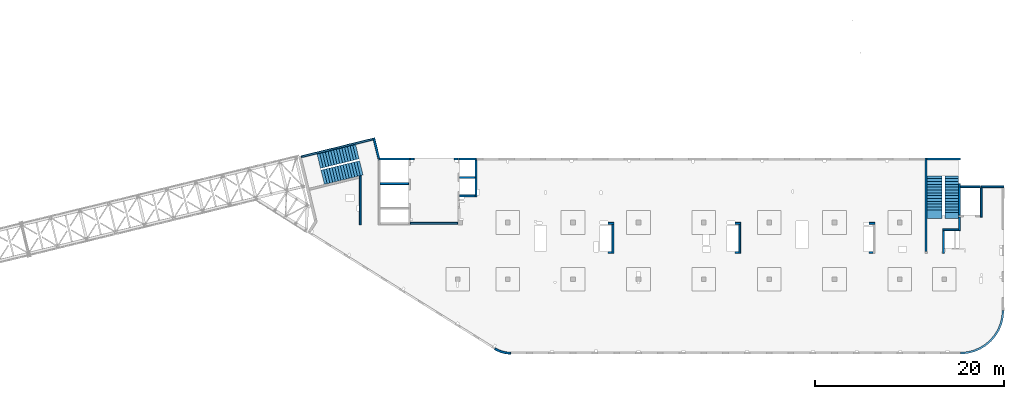
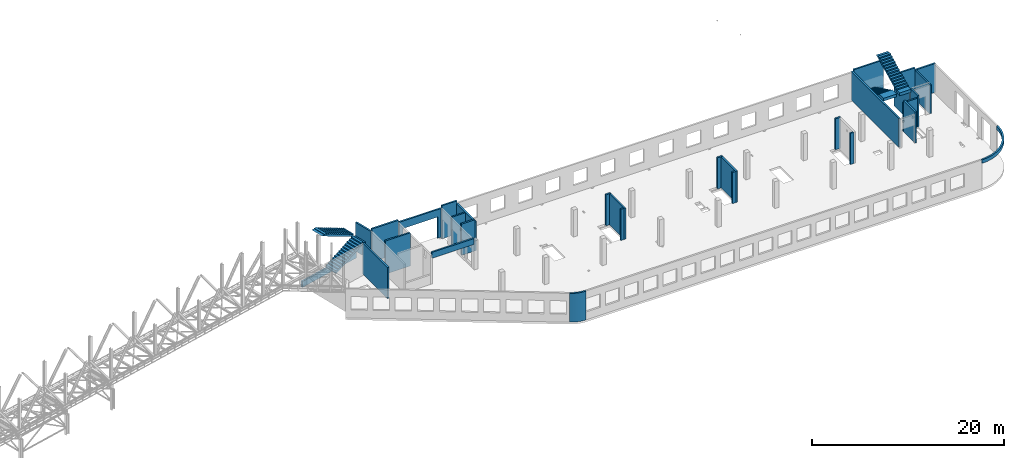
# One storey, part 21 of 93: 30 walls, 4 stairs, 1 opening.
"""IFC4 building model written with IfcOpenShell, lengths in millimetres."""

from ifc_helpers import new_model, entity, si_unit, converted_unit, derived_unit, direction, frame, origin, place, context, subcontext, project, spatial, indexed_curve, outline, extrude, polygons, material, type_object, element, save


model = new_model("IFC4")

# Units and contexts
model_context = context("Model", 3, precision=0.01, world=origin(), true_north=direction((6.12303176911189e-17, 1.0)))
plan_context = context("Plan", 3, precision=0.01, world=origin(), true_north=direction((6.12303176911189e-17, 1.0)))
body_context = subcontext(model_context, "Body", "Model", "MODEL_VIEW")
ifc_project = project(units=[si_unit("LENGTHUNIT", "METRE", prefix="MILLI"), si_unit("AREAUNIT", "SQUARE_METRE"), si_unit("VOLUMEUNIT", "CUBIC_METRE"), converted_unit("PLANEANGLEUNIT", "DEGREE", entity("IfcRatioMeasure", 0.0174532925199433), si_unit("PLANEANGLEUNIT", "RADIAN"), dimensions=[0, 0, 0, 0, 0, 0, 0]), si_unit("MASSUNIT", "GRAM", prefix="KILO"), derived_unit("MASSDENSITYUNIT", [(si_unit("MASSUNIT", "GRAM", prefix="KILO"), 1), (si_unit("LENGTHUNIT", "METRE"), -3)]), derived_unit("MOMENTOFINERTIAUNIT", [(si_unit("LENGTHUNIT", "METRE"), 4)]), si_unit("TIMEUNIT", "SECOND"), si_unit("FREQUENCYUNIT", "HERTZ"), si_unit("THERMODYNAMICTEMPERATUREUNIT", "DEGREE_CELSIUS"), derived_unit("THERMALTRANSMITTANCEUNIT", [(si_unit("MASSUNIT", "GRAM", prefix="KILO"), 1), (si_unit("THERMODYNAMICTEMPERATUREUNIT", "KELVIN"), -1), (si_unit("TIMEUNIT", "SECOND"), -3)]), derived_unit("VOLUMETRICFLOWRATEUNIT", [(si_unit("LENGTHUNIT", "METRE"), 3), (si_unit("TIMEUNIT", "SECOND"), -1)]), derived_unit("MASSFLOWRATEUNIT", [(si_unit("MASSUNIT", "GRAM", prefix="KILO"), 1), (si_unit("TIMEUNIT", "SECOND"), -1)]), derived_unit("ROTATIONALFREQUENCYUNIT", [(si_unit("TIMEUNIT", "SECOND"), -1)]), si_unit("ELECTRICCURRENTUNIT", "AMPERE"), si_unit("ELECTRICVOLTAGEUNIT", "VOLT"), si_unit("POWERUNIT", "WATT"), si_unit("FORCEUNIT", "NEWTON", prefix="KILO"), si_unit("ILLUMINANCEUNIT", "LUX"), si_unit("LUMINOUSFLUXUNIT", "LUMEN"), si_unit("LUMINOUSINTENSITYUNIT", "CANDELA"), derived_unit("USERDEFINED", [(si_unit("MASSUNIT", "GRAM", prefix="KILO"), -1), (si_unit("LENGTHUNIT", "METRE"), -2), (si_unit("TIMEUNIT", "SECOND"), 3), (si_unit("LUMINOUSFLUXUNIT", "LUMEN"), 1)]), derived_unit("LINEARVELOCITYUNIT", [(si_unit("LENGTHUNIT", "METRE"), 1), (si_unit("TIMEUNIT", "SECOND"), -1)]), si_unit("PRESSUREUNIT", "PASCAL"), derived_unit("USERDEFINED", [(si_unit("LENGTHUNIT", "METRE"), -2), (si_unit("MASSUNIT", "GRAM", prefix="KILO"), 1), (si_unit("TIMEUNIT", "SECOND"), -2)]), derived_unit("LINEARFORCEUNIT", [(si_unit("MASSUNIT", "GRAM", prefix="KILO"), 1), (si_unit("LENGTHUNIT", "METRE"), 1), (si_unit("TIMEUNIT", "SECOND"), -2), (si_unit("LENGTHUNIT", "METRE"), -1)]), derived_unit("PLANARFORCEUNIT", [(si_unit("MASSUNIT", "GRAM", prefix="KILO"), 1), (si_unit("LENGTHUNIT", "METRE"), 1), (si_unit("TIMEUNIT", "SECOND"), -2), (si_unit("LENGTHUNIT", "METRE"), -2)])], contexts=[model_context, plan_context])

# Site, building, storey
site_placement = place(None, origin())
site = spatial("IfcSite", under=ifc_project, at=site_placement, CompositionType="ELEMENT")
building_placement = place(site_placement, origin())
building = spatial("IfcBuilding", under=site, at=building_placement, CompositionType="ELEMENT")
storey_placement = place(building_placement, frame((0.0, 0.0, 15900.0)))
storey = spatial("IfcBuildingStorey", under=building, at=storey_placement, CompositionType="ELEMENT", Elevation=15900.0)

# Walls
ifc_material_1 = material()
wall_type = type_object("IfcWallType", PredefinedType="STANDARD")
wall_1_placement = place(storey_placement, frame((71069.9994506836, 17469.9992263555, -150.0)))
element("IfcWall", 1, at=wall_1_placement, inside=storey, type_object=wall_type, material=ifc_material_1, PredefinedType="NOTDEFINED", context=body_context, shape_type="SweptSolid", body=[
    extrude(outline(indexed_curve([(2500.00000000001, -99.9999999999999), (2500.00000000001, 100.0), (99.9999999999943, 99.9999999999992), (99.9999999999949, -100.000000000001), (199.999999999998, -100.0), (2300.00000000001, -100.0), (2500.00000000001, -99.9999999999999)], self_intersect=False)), origin(), (0.0, 0.0, 1.0), 3650.0),
])
wall_2_placement = place(storey_placement, frame((71169.9994506836, 17369.9992263555, -150.0), z_axis=(0.0, 0.0, 1.0), x_axis=(0.0, -1.0, 0.0)))
element("IfcWall", 2, at=wall_2_placement, inside=storey, type_object=wall_type, material=ifc_material_1, PredefinedType="NOTDEFINED", context=body_context, shape_type="SweptSolid", body=[
    extrude(outline(indexed_curve([(3100.0, 100.000000000003), (-2.79449581754433e-13, 100.000000000003), (2.79449581754433e-13, -100.000000000003), (3100.0, -100.000000000003), (3100.0, 100.000000000003)], self_intersect=False)), origin(), (0.0, 0.0, 1.0), 3650.0),
])
wall_3_placement = place(storey_placement, frame((68870.0002685547, 14269.9992263555, -150.0), z_axis=(0.0, 0.0, 1.0), x_axis=(0.0, -1.0, 0.0)))
element("IfcWall", 3, at=wall_3_placement, inside=storey, type_object=wall_type, material=ifc_material_1, PredefinedType="NOTDEFINED", context=body_context, shape_type="SweptSolid", body=[
    extrude(outline(indexed_curve([(1439.99999999999, 100.000000000003), (0.0, 100.000000000003), (0.0, -100.000000000003), (1439.99999999999, -100.000000000003), (1439.99999999999, 100.000000000003)], self_intersect=False)), origin(), (0.0, 0.0, 1.0), 3950.0),
])
wall_4_placement = place(storey_placement, frame((68770.0002685547, 12929.9992263555, -150.0), z_axis=(0.0, 0.0, 1.0), x_axis=(-1.0, 0.0, 0.0)))
element("IfcWall", 4, at=wall_4_placement, inside=storey, type_object=wall_type, material=ifc_material_1, PredefinedType="NOTDEFINED", context=body_context, shape_type="SweptSolid", body=[
    extrude(outline(indexed_curve([(1689.99999999997, 99.9999999999989), (-3.84449868389964e-13, 99.9999999999989), (3.84449868389964e-13, -99.9999999999989), (1689.99999999997, -99.9999999999989), (1689.99999999997, 99.9999999999989)], self_intersect=False)), origin(), (0.0, 0.0, 1.0), 3650.0),
])
wall_5_placement = place(storey_placement, frame((67180.0002685547, 12829.9992263555, -150.0), z_axis=(0.0, 0.0, 1.0), x_axis=(0.0, -1.0, 0.0)))
element("IfcWall", 5, at=wall_5_placement, inside=storey, type_object=wall_type, material=ifc_material_1, PredefinedType="NOTDEFINED", context=body_context, shape_type="SweptSolid", body=[
    extrude(outline(indexed_curve([(2404.99999999995, 100.000000000003), (0.0, 100.000000000003), (0.0, -100.000000000003), (2404.99999999995, -100.000000000003), (2404.99999999995, 100.000000000003)], self_intersect=False)), origin(), (0.0, 0.0, 1.0), 3950.0),
])
wall_6_placement = place(storey_placement, frame((65330.0002685547, 10624.9992263555, -150.0), z_axis=(0.0, 0.0, 1.0), x_axis=(0.0, 1.0, 0.0)))
element("IfcWall", 6, at=wall_6_placement, inside=storey, type_object=wall_type, material=ifc_material_1, PredefinedType="NOTDEFINED", context=body_context, shape_type="SweptSolid", body=[
    extrude(outline(indexed_curve([(9875.00063936713, 100.000000000003), (-1.71685740578866e-13, 100.000000000003), (1.71685740578866e-13, -100.000000000003), (9875.00063936713, -100.000000000004), (9875.00063936713, 100.000000000003)], self_intersect=False)), origin(), (0.0, 0.0, 1.0), 3650.0),
])
wall_7_placement = place(storey_placement, frame((68970.0002685545, -99.9999557734324, 3050.0)))
element("IfcWall", 7, at=wall_7_placement, inside=storey, type_object=wall_type, material=ifc_material_1, PredefinedType="NOTDEFINED", context=body_context, shape_type="SweptSolid", body=[
    extrude(outline(indexed_curve([(4399.99918212903, 4499.99918212888), (4345.82789081698, 3811.68766389508), (4184.64789385715, 3140.32465961517), (3920.42797770043, 2502.44135458057), (3559.67411357824, 1913.74455277455), (3111.26925889869, 1388.72992323025), (2586.25462935438, 940.325068550716), (1997.55782754836, 579.571204428538), (1359.67452251375, 315.351288271842), (688.311518233829, 154.171291312031), (3.46517481375486e-11, 100.0), (0.0, -100.0), (719.598411241839, -43.3663768070014), (1421.47792138871, 125.139985012801), (2088.35592749623, 401.369899590849), (2703.81167981284, 778.521669675706), (3252.69061513597, 1247.30856699292), (3721.47751245321, 1796.18750231603), (4098.6292825381, 2411.64325463263), (4374.85919711618, 3078.52126074015), (4543.365558936, 3780.40077088701), (4599.99918212903, 4499.99918212885), (4399.99918212903, 4499.99918212888)], self_intersect=False)), origin(), (0.0, 0.0, 1.0), 450.000000000002),
])
wall_8_placement = place(storey_placement, frame((19822.3508916672, 371.159404898124, -150.0)))
element("IfcWall", 8, at=wall_8_placement, inside=storey, type_object=wall_type, material=ifc_material_1, PredefinedType="NOTDEFINED", context=body_context, shape_type="SweptSolid", body=[
    extrude(outline(indexed_curve([(1647.48298908956, -371.159642137684), (1479.53495854193, -366.732336838998), (1312.09852486252, -352.905454552832), (1145.69934172072, -329.72240370142), (980.859806418502, -297.255965670987), (818.09741986465, -255.608066320247), (657.923161920899, -204.909455992096), (500.839887220395, -145.319299033065), (347.340746494629, -77.024674109233), (197.907638365059, -0.239986887291593), (53.0096964598414, 84.7937030753815), (-53.0096964598197, -84.7937030753918), (101.553010904459, -175.499182842681), (260.953382356765, -257.405447245706), (424.69099282044, -330.255357933605), (592.251800794088, -393.820208274097), (763.109762144871, -447.900441360165), (936.728481583211, -492.326276503471), (1112.5628966341, -526.958242247616), (1290.06098881835, -551.687614227945), (1468.66551667174, -566.436756503237), (1647.81576516126, -571.159365287708), (1647.48298908956, -371.159642137684)], self_intersect=False)), origin(), (0.0, 0.0, 1.0), 3650.0),
])
wall_9_placement = place(storey_placement, frame((17825.0002685547, 20299.9998657227, -150.0), z_axis=(0.0, 0.0, 1.0), x_axis=(0.0, -1.0, 0.0)))
element("IfcWall", 9, at=wall_9_placement, inside=storey, type_object=wall_type, material=ifc_material_1, PredefinedType="NOTDEFINED", context=body_context, shape_type="SweptSolid", body=[
    extrude(outline(indexed_curve([(3900.00063936684, 99.9999999999989), (-1.66594915657375e-13, 99.9999999999989), (1.66594915657375e-13, -99.9999999999989), (3900.00063936684, -99.9999999999989), (3900.00063936684, 99.9999999999989)], self_intersect=False)), origin(), (0.0, 0.0, 1.0), 3650.0),
])
wall_10_placement = place(storey_placement, frame((17725.0002685547, 16499.9992263558, -150.0), z_axis=(0.0, 0.0, 1.0), x_axis=(-1.0, 0.0, 0.0)))
element("IfcWall", 10, at=wall_10_placement, inside=storey, type_object=wall_type, material=ifc_material_1, PredefinedType="NOTDEFINED", context=body_context, shape_type="SweptSolid", body=[
    extrude(outline(indexed_curve([(1624.99999999999, 99.9999999999982), (-3.56011111002209e-13, 99.9999999999989), (3.56011111002209e-13, -99.9999999999989), (1624.99999999999, -99.9999999999996), (1624.99999999999, 99.9999999999982)], self_intersect=False)), origin(), (0.0, 0.0, 1.0), 3950.0),
])
wall_11_placement = place(storey_placement, frame((5600.00026855469, 13449.9992263559, -150.0), z_axis=(0.0, 0.0, 1.0), x_axis=(0.0, 1.0, 0.0)))
element("IfcWall", 11, at=wall_11_placement, inside=storey, type_object=wall_type, material=ifc_material_1, PredefinedType="NOTDEFINED", context=body_context, shape_type="SweptSolid", body=[
    extrude(outline(indexed_curve([(5191.05764338749, -100.0), (5142.30552742916, 99.9999999999995), (4936.44934265344, 100.0), (-1.37676332088153e-13, 100.0), (1.37676332088153e-13, -100.0), (5191.05764338749, -100.0)], self_intersect=False)), origin(), (0.0, 0.0, 1.0), 3950.0),
])

# Wall, opening
wall_12_placement = place(storey_placement, frame((10900.0002685547, 20399.9998657227, -150.0)))
wall_12 = element("IfcWall", 12, at=wall_12_placement, inside=storey, type_object=wall_type, material=ifc_material_1, PredefinedType="NOTDEFINED", context=body_context, shape_type="Tessellation", body=[
    polygons([(5000.0, -100.000000000003, 3650.0), (-4.99784381508401e-13, -100.000000000003, 3650.0), (-4.99784381508401e-13, -100.000000000003, -2.16573425859679e-12), (399.999999999991, -99.9999999999989, -2.16573425859679e-12), (399.999999999993, -100.000000000003, 2699.99999999805), (4599.99999999999, -100.000000000003, 2699.99999999804), (4599.99999999999, -100.000000000003, -2.16573425859679e-12), (5000.0, -100.000000000003, -2.16573425859679e-12), (-1.16616415338434e-12, 99.9999999999989, 3650.0), (5000.0, 99.9999999999989, 3650.0), (5000.0, 99.9999999999989, 49.9999999999973), (5000.0, 99.9999999999989, -2.16573425859679e-12), (4599.99999999999, 99.9999999999989, -2.16573425859679e-12), (4599.99999999999, 99.9999999999989, 2699.99999999804), (399.999999999992, 100.000000000003, 2699.99999999805), (399.999999999992, 100.000000000003, -2.16573425859679e-12), (-1.16616415338434e-12, 99.9999999999989, -2.16573425859679e-12), (-1.16616415338434e-12, 99.9999999999989, 49.9999999999973)], [[[1, 2, 3, 4, 5, 6, 7, 8]], [[9, 10, 11, 12, 13, 14, 15, 16, 17, 18]], [[3, 17, 16, 4]], [[2, 1, 10, 9]], [[5, 15, 14, 6]], [[6, 14, 13, 7]], [[15, 5, 4, 16]], [[8, 12, 11, 10, 1]], [[17, 3, 2, 9, 18]], [[12, 8, 7, 13]]], closed=True),
])
opening_placement = place(wall_12_placement, frame((-10900.0002685547, -20399.9998657227, 150.0)))
element("IfcOpeningElement", 13, at=opening_placement, cuts=wall_12, PredefinedType="OPENING", context=body_context, shape_type="SweptSolid", body=[
    extrude(outline(indexed_curve([(-2100.0, -1349.99999999902), (2100.0, -1349.99999999902), (2100.0, 1349.99999999902), (-2100.0, 1349.99999999902), (-2100.0, -1349.99999999902)], self_intersect=False)), frame((13400.0002685547, 20199.9998657207, 1200.0), z_axis=(0.0, 1.0, 0.0), x_axis=(1.0, 0.0, 0.0)), (0.0, 0.0, 1.0), 400.000000001945),
])

# Walls
wall_13_placement = place(storey_placement, frame((68870.0002685547, 17779.9992263555, -400.0), z_axis=(0.0, 0.0, 1.0), x_axis=(0.0, -1.0, 0.0)))
element("IfcWall", 14, at=wall_13_placement, inside=storey, type_object=wall_type, material=ifc_material_1, PredefinedType="NOTDEFINED", context=body_context, shape_type="Tessellation", body=[
    polygons([(2.16573425859679e-12, -99.9999999999946, 0.0), (3310.0, -99.9999999999946, 0.0), (3310.0, -99.9999999999946, 299.999999999997), (3310.0, -99.9999999999946, 3900.0), (2.16573425859679e-12, -99.9999999999946, 3900.0), (3310.0, 100.000000000012, 0.0), (410.0, 100.000000000003, 0.0), (210.0, 100.000000000003, 0.0), (2.16573425859679e-12, 100.000000000012, 0.0), (2.16573425859679e-12, 100.000000000012, 3900.0), (3310.0, 100.000000000012, 3900.0)], [[[1, 2, 3, 4, 5]], [[6, 7, 8, 9, 10, 11]], [[2, 1, 9, 8, 7, 6]], [[9, 1, 5, 10]], [[2, 6, 11, 4, 3]], [[5, 4, 11, 10]]], closed=True),
])
wall_14_placement = place(storey_placement, frame((68970.0002685547, 17469.9992263555, -100.0)))
element("IfcWall", 15, at=wall_14_placement, inside=storey, type_object=wall_type, material=ifc_material_1, PredefinedType="NOTDEFINED", context=body_context, shape_type="Tessellation", body=[
    polygons([(2099.99918212888, -100.000000000001, 2.16573425859679e-12), (2099.99918212888, -100.000000000001, 3600.0), (2099.99918212888, -100.000000000001, 3850.0), (2099.99918212888, -100.000000000001, 3900.0), (6.89939203009021e-12, -100.000000000001, 3900.0), (6.89939203009021e-12, -100.000000000001, 2.16573425859679e-12), (6.28061057235613e-12, 99.9999999999989, 3900.0), (2099.99918212888, 99.9999999999989, 3900.0), (2099.99918212888, 99.9999999999989, 3850.0), (2099.99918212888, 99.9999999999989, 3600.0), (2099.99918212888, 99.9999999999989, 2.16573425859679e-12), (6.28061057235613e-12, 99.9999999999989, 2.16573425859679e-12)], [[[1, 2, 3, 4, 5, 6]], [[7, 8, 9, 10, 11, 12]], [[5, 4, 8, 7]], [[5, 7, 12, 6]], [[1, 11, 10, 9, 8, 4, 3, 2]], [[1, 6, 12, 11]]], closed=True),
])
wall_15_placement = place(storey_placement, frame((65430.0002685547, 20399.9998657227, -400.0)))
element("IfcWall", 16, at=wall_15_placement, inside=storey, type_object=wall_type, material=ifc_material_1, PredefinedType="NOTDEFINED", context=body_context, shape_type="SweptSolid", body=[
    extrude(outline(indexed_curve([(3539.99999999995, 99.9999999999989), (-3.67073603151997e-13, 99.9999999999989), (3.67073603151997e-13, -99.9999999999989), (3539.99999999995, -99.9999999999989), (3539.99999999995, 99.9999999999989)], self_intersect=False)), origin(), (0.0, 0.0, 1.0), 4150.0),
])
wall_16_placement = place(storey_placement, frame((16000.0002685547, 20399.9998657227, -400.0)))
element("IfcWall", 17, at=wall_16_placement, inside=storey, type_object=wall_type, material=ifc_material_1, PredefinedType="NOTDEFINED", context=body_context, shape_type="SweptSolid", body=[
    extrude(outline(indexed_curve([(1824.99999999999, -100.000000000003), (1824.99999999999, 99.9999999999995), (1724.99999999999, 99.9999999999992), (99.9999999999987, 99.9999999999992), (-2.66551908750372e-13, 99.9999999999989), (2.66551908750383e-13, -100.000000000003), (1724.99999999999, -100.000000000003), (1824.99999999999, -100.000000000003)], self_intersect=False)), origin(), (0.0, 0.0, 1.0), 4200.0),
])
wall_17_placement = place(storey_placement, frame((16100.0002685547, 18449.9998657227, -400.0)))
element("IfcWall", 18, at=wall_17_placement, inside=storey, type_object=wall_type, material=ifc_material_1, PredefinedType="NOTDEFINED", context=body_context, shape_type="SweptSolid", body=[
    extrude(outline(indexed_curve([(1624.99999999999, 99.9999999999989), (-2.66551908750371e-13, 99.9999999999989), (2.66551908750371e-13, -99.9999999999989), (1624.99999999999, -99.9999999999989), (1624.99999999999, 99.9999999999989)], self_intersect=False)), origin(), (0.0, 0.0, 1.0), 3900.0),
])
wall_18_placement = place(storey_placement, frame((7600.0002685547, 20399.9998657227, -400.0)))
element("IfcWall", 19, at=wall_18_placement, inside=storey, type_object=wall_type, material=ifc_material_1, PredefinedType="NOTDEFINED", context=body_context, shape_type="SweptSolid", body=[
    extrude(outline(indexed_curve([(3200.0, -100.000000000003), (3200.0, 99.9999999999995), (3100.0, 99.9999999999992), (7.9410256148549e-13, 99.9999999999989), (2.88764567812915e-13, -100.000000000003), (3200.0, -100.000000000003)], self_intersect=False)), origin(), (0.0, 0.0, 1.0), 4200.0),
])
wall_19_placement = place(storey_placement, frame((7700.0002685547, 17799.9998657227, -400.0)))
element("IfcWall", 20, at=wall_19_placement, inside=storey, type_object=wall_type, material=ifc_material_1, PredefinedType="NOTDEFINED", context=body_context, shape_type="SweptSolid", body=[
    extrude(outline(indexed_curve([(3000.0, 99.9999999999989), (-2.88764567812902e-13, 99.9999999999989), (2.88764567812902e-13, -99.9999999999989), (3000.0, -99.9999999999989), (3000.0, 99.9999999999989)], self_intersect=False)), origin(), (0.0, 0.0, 1.0), 4200.0),
])
wall_20_placement = place(storey_placement, frame((59330.0002685547, 13599.9992263555, -150.0)))
element("IfcWall", 21, at=wall_20_placement, inside=storey, type_object=wall_type, material=ifc_material_1, PredefinedType="NOTDEFINED", context=body_context, shape_type="SweptSolid", body=[
    extrude(outline(indexed_curve([(599.999999999993, 99.9999999999989), (-3.60955709766131e-13, 99.9999999999989), (3.60955709766131e-13, -99.9999999999989), (599.999999999994, -99.9999999999989), (599.999999999993, 99.9999999999989)], self_intersect=False)), origin(), (0.0, 0.0, 1.0), 3950.0),
])
wall_21_placement = place(storey_placement, frame((59730.0002685547, 10524.9992263555, -150.0), z_axis=(0.0, 0.0, 1.0), x_axis=(-1.0, 0.0, 0.0)))
element("IfcWall", 22, at=wall_21_placement, inside=storey, type_object=wall_type, material=ifc_material_1, PredefinedType="NOTDEFINED", context=body_context, shape_type="SweptSolid", body=[
    extrude(outline(indexed_curve([(399.999999999987, 99.9999999999982), (-3.60955709766136e-13, 99.9999999999989), (3.60955709766136e-13, -99.9999999999989), (399.999999999987, -99.9999999999996), (399.999999999987, 99.9999999999982)], self_intersect=False)), origin(), (0.0, 0.0, 1.0), 3950.0),
])
wall_22_placement = place(storey_placement, frame((45170.0002685547, 13599.9992263556, -150.0)))
element("IfcWall", 23, at=wall_22_placement, inside=storey, type_object=wall_type, material=ifc_material_1, PredefinedType="NOTDEFINED", context=body_context, shape_type="SweptSolid", body=[
    extrude(outline(indexed_curve([(599.999999999993, 99.9999999999989), (-3.60955709766131e-13, 99.9999999999989), (3.60955709766131e-13, -99.9999999999989), (599.999999999994, -99.9999999999989), (599.999999999993, 99.9999999999989)], self_intersect=False)), origin(), (0.0, 0.0, 1.0), 3950.0),
])
wall_23_placement = place(storey_placement, frame((45670.0002685547, 13499.9992263556, -150.0), z_axis=(0.0, 0.0, 1.0), x_axis=(0.0, -1.0, 0.0)))
element("IfcWall", 24, at=wall_23_placement, inside=storey, type_object=wall_type, material=ifc_material_1, PredefinedType="NOTDEFINED", context=body_context, shape_type="SweptSolid", body=[
    extrude(outline(indexed_curve([(3074.99985044015, 100.000000000003), (-2.64517173435081e-13, 100.000000000003), (2.64517173435081e-13, -100.000000000003), (3074.99985044015, -100.000000000004), (3074.99985044015, 100.000000000003)], self_intersect=False)), origin(), (0.0, 0.0, 1.0), 3950.0),
])
wall_24_placement = place(storey_placement, frame((45570.0002685547, 10524.9993759154, -150.0), z_axis=(0.0, 0.0, 1.0), x_axis=(-1.0, 0.0, 0.0)))
element("IfcWall", 25, at=wall_24_placement, inside=storey, type_object=wall_type, material=ifc_material_1, PredefinedType="NOTDEFINED", context=body_context, shape_type="SweptSolid", body=[
    extrude(outline(indexed_curve([(399.999999999995, 99.9999999999982), (-3.60955709766131e-13, 99.9999999999989), (3.60955709766131e-13, -99.9999999999989), (399.999999999996, -99.9999999999996), (399.999999999995, 99.9999999999982)], self_intersect=False)), origin(), (0.0, 0.0, 1.0), 3950.0),
])
wall_25_placement = place(storey_placement, frame((31770.0002685547, 13599.9992263557, -150.0)))
element("IfcWall", 26, at=wall_25_placement, inside=storey, type_object=wall_type, material=ifc_material_1, PredefinedType="NOTDEFINED", context=body_context, shape_type="SweptSolid", body=[
    extrude(outline(indexed_curve([(600.000000000002, 99.9999999999989), (-3.60955709766126e-13, 99.9999999999989), (3.60955709766126e-13, -99.9999999999989), (600.000000000003, -99.9999999999989), (600.000000000002, 99.9999999999989)], self_intersect=False)), origin(), (0.0, 0.0, 1.0), 3950.0),
])
wall_26_placement = place(storey_placement, frame((32270.0002685547, 13499.9992263557, -150.0), z_axis=(0.0, 0.0, 1.0), x_axis=(0.0, -1.0, 0.0)))
element("IfcWall", 27, at=wall_26_placement, inside=storey, type_object=wall_type, material=ifc_material_1, PredefinedType="NOTDEFINED", context=body_context, shape_type="SweptSolid", body=[
    extrude(outline(indexed_curve([(3074.99985044025, 99.9999999999987), (-1.32258586717531e-13, 99.9999999999989), (1.32258586717531e-13, -99.9999999999989), (3074.99985044025, -99.9999999999992), (3074.99985044025, 99.9999999999987)], self_intersect=False)), origin(), (0.0, 0.0, 1.0), 3950.0),
])
wall_27_placement = place(storey_placement, frame((32170.0002685547, 10524.9993759155, -150.0), z_axis=(0.0, 0.0, 1.0), x_axis=(-1.0, 0.0, 0.0)))
element("IfcWall", 28, at=wall_27_placement, inside=storey, type_object=wall_type, material=ifc_material_1, PredefinedType="NOTDEFINED", context=body_context, shape_type="SweptSolid", body=[
    extrude(outline(indexed_curve([(399.999999999995, 99.9999999999982), (-3.60955709766131e-13, 99.9999999999989), (3.60955709766131e-13, -99.9999999999989), (399.999999999996, -99.9999999999996), (399.999999999995, 99.9999999999982)], self_intersect=False)), origin(), (0.0, 0.0, 1.0), 3950.0),
])
wall_28_placement = place(storey_placement, frame((10900.0002685547, 13599.9992263559, 3050.0)))
element("IfcWall", 29, at=wall_28_placement, inside=storey, type_object=wall_type, material=ifc_material_1, PredefinedType="NOTDEFINED", context=body_context, shape_type="SweptSolid", body=[
    extrude(outline(indexed_curve([(4999.99925537109, 99.9999999999989), (-3.03202841358267e-13, 99.9999999999989), (3.03202841358267e-13, -99.9999999999989), (4999.99925537109, -99.9999999999989), (4999.99925537109, 99.9999999999989)], self_intersect=False)), origin(), (0.0, 0.0, 1.0), 749.999999999998),
])
wall_29_placement = place(storey_placement, frame((7033.44218130896, 22609.751914045, -150.0), z_axis=(0.0, 0.0, 1.0), x_axis=(0.236826092990327, -0.971552058141475, 0.0)))
element("IfcWall", 30, at=wall_29_placement, inside=storey, type_object=wall_type, material=ifc_material_1, PredefinedType="NOTDEFINED", context=body_context, shape_type="SweptSolid", body=[
    extrude(outline(indexed_curve([(2380.28371765147, -100.0), (2354.53748529952, -93.7240834744374), (2160.22707367122, -46.3588648763715), (2195.90359543113, 99.9999999999993), (-1.90347737571983e-13, 99.9999999999987), (-6.76791955811495e-14, -99.9999999999997), (199.999999999995, -99.9999999999999), (2380.28371765147, -100.0)], self_intersect=False)), origin(), (0.0, 0.0, 1.0), 3650.0),
])
wall_30_placement = place(storey_placement, frame((-618.128763974208, 20641.672451718, -900.0), z_axis=(0.0, 0.0, 1.0), x_axis=(0.971552058141473, 0.236826092990338, 0.0)))
element("IfcWall", 31, at=wall_30_placement, inside=storey, type_object=wall_type, material=ifc_material_1, PredefinedType="NOTDEFINED", context=body_context, shape_type="SweptSolid", body=[
    extrude(outline(indexed_curve([(7799.9920696628, 100.000000000001), (-5.4989346409684e-14, 100.0), (5.4989346409684e-14, -100.0), (7799.9920696628, -99.9999999999997), (7799.9920696628, 100.000000000001)], self_intersect=False)), origin(), (0.0, 0.0, 1.0), 750.000000000003),
])

# Stairs
ifc_material_2 = material()
stair_type_1 = type_object("IfcStairType", PredefinedType="HALF_TURN_STAIR")
stair_1_placement = place(storey_placement, origin())
element("IfcStair", 32, at=stair_1_placement, inside=storey, type_object=stair_type_1, material=ifc_material_2, PredefinedType="HALF_TURN_STAIR", context=body_context, shape_type="SweptSolid", body=[
    extrude(outline(indexed_curve([(919.999999999986, -2328.92203609093), (1289.99999999999, -2328.92203609093), (1289.99999999999, -2021.70844059097), (-980.000000000011, 2518.29155940903), (-980.000000000011, 2171.07796390909), (-1030.00000000001, 2171.07796390909), (-1030.00000000001, 1871.07796390909), (-880.000000000016, 1871.07796390909), (-880.000000000016, 1571.07796390909), (-730.000000000016, 1571.07796390909), (-730.000000000016, 1271.07796390908), (-580.000000000015, 1271.07796390908), (-580.000000000015, 971.077963909084), (-430.000000000015, 971.077963909084), (-430.000000000015, 671.077963909082), (-280.000000000014, 671.077963909082), (-280.000000000014, 371.077963909081), (-130.000000000014, 371.077963909081), (-130.000000000014, 71.0779639090803), (19.9999999999868, 71.0779639090803), (19.9999999999868, -228.922036090921), (169.999999999987, -228.922036090921), (169.999999999987, -528.922036090922), (319.999999999988, -528.922036090922), (319.999999999988, -828.922036090923), (469.999999999988, -828.922036090923), (469.999999999988, -1128.92203609092), (619.999999999989, -1128.92203609092), (619.999999999989, -1428.92203609093), (769.999999999985, -1428.92203609093), (769.999999999985, -1728.92203609093), (919.999999999986, -1728.92203609093), (919.999999999986, -2328.92203609093)], self_intersect=False)), frame((67360.0002685547, 16458.9212624464, 4790.0), z_axis=(1.0, 0.0, 0.0), x_axis=(0.0, 0.0, -1.0)), (0.0, 0.0, 1.0), 1390.0),
])
stair_type_2 = type_object("IfcStairType", PredefinedType="HALF_TURN_STAIR")
stair_2_placement = place(storey_placement, origin())
element("IfcStair", 33, at=stair_2_placement, inside=storey, type_object=stair_type_2, material=ifc_material_2, PredefinedType="HALF_TURN_STAIR", context=body_context, shape_type="SweptSolid", body=[
    extrude(outline(indexed_curve([(-1981.81423970003, -851.999999999993), (-1981.81423970003, -1201.99999999999), (-1934.60064420008, -1202.0), (1625.39935579994, 578.000000000007), (2518.18576030048, 578.000000000009), (2518.18576030048, 948.000000000005), (1618.18576029998, 948.000000000005), (1618.18576029998, 798.000000000009), (1318.18576029998, 798.000000000009), (1318.18576029998, 648.000000000009), (1018.18576029998, 648.000000000009), (1018.18576029998, 498.000000000008), (718.185760299978, 498.000000000008), (718.185760299978, 348.000000000008), (418.185760299977, 348.000000000008), (418.185760299977, 198.000000000007), (118.185760299976, 198.000000000007), (118.185760299976, 48.0000000000086), (-181.814239700026, 48.0000000000086), (-181.814239700026, -101.999999999992), (-481.814239700027, -101.999999999992), (-481.814239700027, -251.999999999993), (-781.814239700028, -251.999999999993), (-781.814239700028, -401.999999999991), (-1081.81423970003, -401.999999999991), (-1081.81423970003, -551.999999999991), (-1381.81423970003, -551.999999999991), (-1381.81423970003, -701.999999999992), (-1681.81423970003, -701.999999999992), (-1681.81423970003, -851.999999999993), (-1981.81423970003, -851.999999999993)], self_intersect=False)), frame((65450.0002685547, 16648.184986656, 2922.0), z_axis=(-1.0, 0.0, 0.0), x_axis=(0.0, -1.0, 0.0)), (0.0, 0.0, -1.0), 1550.0),
])
stair_type_3 = type_object("IfcStairType", PredefinedType="HALF_TURN_STAIR")
stair_3_placement = place(storey_placement, origin())
element("IfcStair", 34, at=stair_3_placement, inside=storey, type_object=stair_type_3, material=ifc_material_2, PredefinedType="HALF_TURN_STAIR", context=body_context, shape_type="SweptSolid", body=[
    extrude(outline(indexed_curve([(948.749999999984, -2110.21875405692), (1318.74999999998, -2110.21875405692), (1318.74999999999, -2103.9509192873), (-951.250000000018, 2436.0490807128), (-951.250000000018, 2088.83548521281), (-1001.25000000001, 2088.83548521281), (-1001.25000000001, 1788.83548521281), (-851.250000000006, 1788.83548521281), (-851.250000000006, 1488.83548521281), (-701.250000000005, 1488.83548521281), (-701.250000000005, 1188.8354852128), (-551.250000000005, 1188.8354852128), (-551.250000000005, 888.835485212796), (-401.250000000008, 888.835485212795), (-401.250000000008, 588.835485212792), (-251.250000000008, 588.835485212791), (-251.250000000008, 288.835485212788), (-101.250000000012, 288.835485212787), (-101.250000000012, -11.1645147872136), (48.7499999999889, -11.1645147872147), (48.7499999999889, -311.164514787218), (198.749999999989, -311.16451478722), (198.749999999989, -611.164514787222), (348.749999999986, -611.164514787223), (348.749999999986, -911.164514787227), (498.749999999986, -911.164514787228), (498.749999999986, -1211.16451478723), (648.749999999982, -1211.16451478723), (648.749999999982, -1511.16451478723), (798.749999999983, -1511.16451478723), (798.749999999983, -1810.69163442208), (948.749999999984, -1810.69163442208), (948.749999999984, -2110.21875405692)], self_intersect=False)), frame((3429.27516319341, 19909.3708367781, 4818.74999999998), z_axis=(-0.236826092990677, 0.97155205814139, 0.0), x_axis=(0.0, 0.0, -1.0)), (0.0, 0.0, 1.0), 1550.00000000006),
])
stair_type_4 = type_object("IfcStairType", PredefinedType="HALF_TURN_STAIR")
stair_4_placement = place(storey_placement, origin())
element("IfcStair", 35, at=stair_4_placement, inside=storey, type_object=stair_type_4, material=ifc_material_2, PredefinedType="HALF_TURN_STAIR", context=body_context, shape_type="SweptSolid", body=[
    extrude(outline(indexed_curve([(-2082.95035407268, -903.75), (-2082.95035407268, -1253.75), (-2035.73675857273, -1253.75), (1524.26324142725, 526.249999999975), (2117.0417155901, 526.249999999973), (2117.0417155901, 776.249999999969), (1817.04964592736, 776.249999999971), (1817.04964592736, 896.250000000004), (1517.04964592735, 896.250000000006), (1517.04964592736, 746.250000000006), (1217.04964592735, 746.250000000008), (1217.04964592735, 596.250000000005), (917.049645927346, 596.250000000005), (917.049645927346, 446.250000000005), (617.049645927341, 446.250000000005), (617.049645927341, 296.250000000004), (317.049645927337, 296.250000000004), (317.049645927336, 146.250000000003), (17.0496459273316, 146.250000000003), (17.0496459273305, -3.74999999999711), (-282.950354072672, -3.74999999999711), (-282.950354072672, -153.749999999998), (-582.950354072676, -153.749999999998), (-582.950354072676, -303.749999999998), (-882.950354072679, -303.749999999998), (-882.950354072679, -453.749999999999), (-1182.95035407268, -453.749999999999), (-1182.95035407268, -603.749999999999), (-1482.95035407268, -603.749999999999), (-1482.95035407268, -753.75), (-1782.95035407268, -753.75), (-1782.95035407268, -903.75), (-2082.95035407268, -903.75)], self_intersect=False)), frame((3838.00311465483, 18207.7609824159, 2973.75000000002), z_axis=(0.236826092990333, -0.971552058141474, 0.0), x_axis=(0.971552058141474, 0.236826092990333, 0.0)), (0.0, 0.0, -1.0), 1550.0),
])

save(model, "model.ifc")
